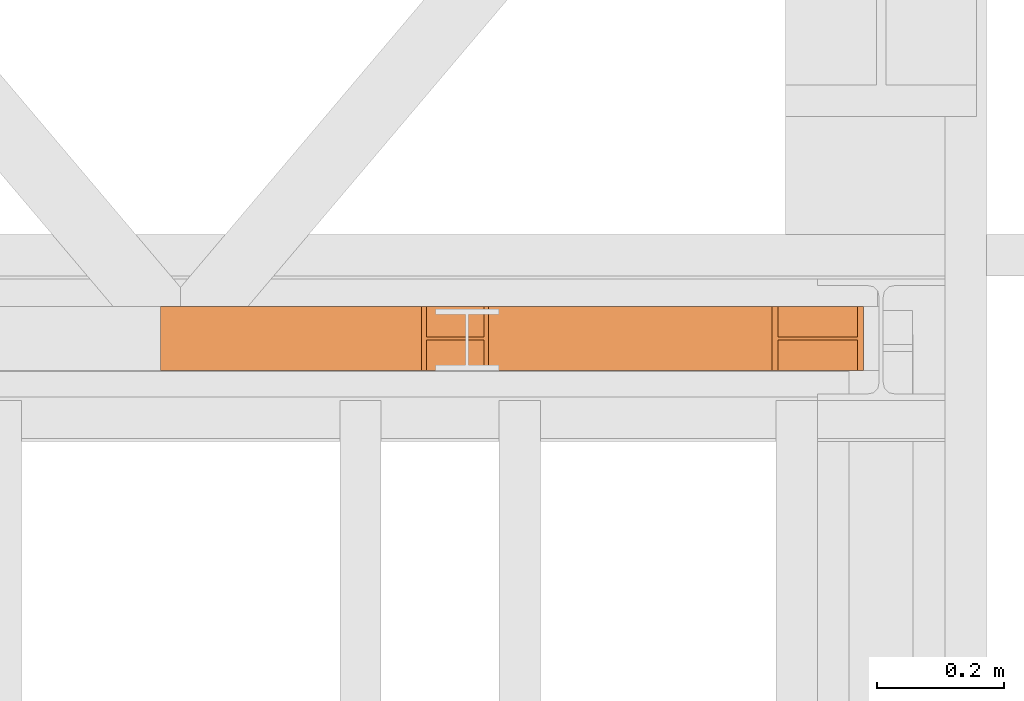
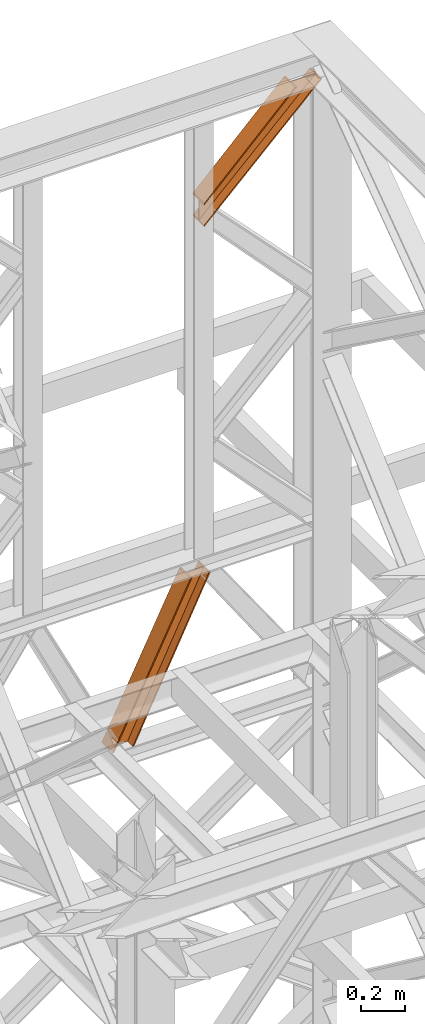
# One storey, part 207 of 208: 2 proxies.
"""IFC2X3 building model written with IfcOpenShell, lengths in millimetres."""

from ifc_helpers import new_model, entity, si_unit, converted_unit, frame, origin, origin_with_axes, place, context, subcontext, project, spatial, faceted_brep, element, save


model = new_model("IFC2X3")

# Units and contexts
model_context = context("Model", 3, precision=1e-05, world=origin())
plan_context = context("Plan", 3, precision=1e-05, world=origin())
body_context = subcontext(model_context, "Body", "Model", "MODEL_VIEW")
ifc_project = project(units=[si_unit("LENGTHUNIT", "METRE", prefix="MILLI"), converted_unit("PLANEANGLEUNIT", "DEGREE", entity("IfcPlaneAngleMeasure", 0.0174532925199433), si_unit("PLANEANGLEUNIT", "RADIAN"), dimensions=[0, 0, 0, 0, 0, 0, 0]), si_unit("AREAUNIT", "SQUARE_METRE"), si_unit("VOLUMEUNIT", "CUBIC_METRE")], contexts=[model_context, plan_context])

# Building, storey
building_placement = place(None, origin())
building = spatial("IfcBuilding", under=ifc_project, at=building_placement, CompositionType="COMPLEX")
storey_placement = place(building_placement, origin_with_axes())
storey = spatial("IfcBuildingStorey", under=building, at=storey_placement, Name="Geschoss", CompositionType="ELEMENT")

# Proxies
proxy_1_placement = place(storey_placement, frame((8143.254968528664, -13810.57439404318, 11640.28097264272), z_axis=(0.0, 0.0, 1.0), x_axis=(1.0, 0.0, 0.0)))
element("IfcBuildingElementProxy", 1, at=proxy_1_placement, inside=storey, context=body_context, shape_type="Brep", body=[
    faceted_brep([(487.7698797118947, 0.01000000000021828, 609.7190860510873), (0.01000000000112777, 0.01000000000021828, 120.9016769489845), (0.01000000000112777, 0.01000000000021828, 130.8127730178949), (478.5483619653542, 0.01000000000021828, 609.7190860510873), (478.5483619653542, 0.01000000000021828, 609.7190860510873), (0.01000000000112777, 0.01000000000021828, 130.8127730178949), (0.01000000000476575, 100.0100000000002, 130.8127730179022), (478.5483619653523, 100.0100000000002, 609.7190860510873), (478.5483619653523, 100.0100000000002, 609.7190860510873), (0.01000000000476575, 100.0100000000002, 130.8127730179022), (0.01000000000112777, 100.0100000000002, 120.9016769489845), (487.7698797118947, 100.0100000000002, 609.7190860510873), (487.7698797118947, 100.0100000000002, 609.7190860510873), (0.01000000000112777, 100.0100000000002, 120.9016769489845), (0.01000000000021828, 52.51000000000022, 120.9016769489808), (487.7698797118965, 52.51000000000022, 609.7190860510873), (487.7698797118965, 52.51000000000022, 609.7190860510873), (0.01000000000021828, 52.51000000000022, 120.9016769489808), (0.01000000000112777, 52.51000000000022, 9.871029833511784), (612.9405080443221, 52.51000000000022, 609.7190860510873), (612.9405080443221, 52.51000000000022, 609.7190860510873), (0.01000000000112777, 52.51000000000022, 9.871029833511784), (0.01000000000112777, 100.0100000000002, 9.871029833511784), (612.9405080443221, 100.0100000000002, 609.7190860510909), (612.9405080443221, 100.0100000000002, 609.7190860510909), (0.01000000000112777, 100.0100000000002, 9.871029833511784), (0.01000000000112777, 100.0100000000002, 0.01000000000021828), (622.1621300498164, 100.0100000000002, 609.7190860510909), (622.1621300498164, 100.0100000000002, 609.7190860510909), (0.01000000000112777, 100.0100000000002, 0.01000000000021828), (0.01000000000112777, 0.01000000000021828, 0.01000000000021828), (622.1621300498127, 0.01000000000021828, 609.7190860510837), (622.1621300498127, 0.01000000000021828, 609.7190860510837), (0.01000000000112777, 0.01000000000021828, 0.01000000000021828), (0.01000000000112777, 0.01000000000021828, 9.871029833511784), (612.9405080443166, 0.01000000000021828, 609.7190860510873), (612.9405080443166, 0.01000000000021828, 609.7190860510873), (0.01000000000112777, 0.01000000000021828, 9.871029833511784), (0.01000000000112777, 47.51000000000022, 9.871029833511784), (612.9405080443184, 47.51000000000022, 609.7190860510909), (612.9405080443184, 47.51000000000022, 609.7190860510909), (0.01000000000112777, 47.51000000000022, 9.871029833511784), (0.01000000000112777, 47.51000000000022, 120.9016769489845), (487.7698797118947, 47.51000000000022, 609.7190860510873), (487.7698797118947, 47.51000000000022, 609.7190860510873), (0.01000000000112777, 47.51000000000022, 120.9016769489845), (0.01000000000112777, 0.01000000000021828, 120.9016769489845), (487.7698797118947, 0.01000000000021828, 609.7190860510873), (0.01000000000112777, 0.01000000000021828, 120.9016769489845), (0.01000000000112777, 47.51000000000022, 120.9016769489845), (0.01000000000112777, 47.51000000000022, 9.871029833511784), (0.01000000000112777, 0.01000000000021828, 9.871029833511784), (0.01000000000112777, 0.01000000000021828, 0.01000000000021828), (0.01000000000112777, 100.0100000000002, 0.01000000000021828), (0.01000000000112777, 100.0100000000002, 9.871029833511784), (0.01000000000112777, 52.51000000000022, 9.871029833511784), (0.01000000000021828, 52.51000000000022, 120.9016769489808), (0.01000000000112777, 100.0100000000002, 120.9016769489845), (0.01000000000476575, 100.0100000000002, 130.8127730179022), (0.01000000000112777, 0.01000000000021828, 130.8127730178949), (478.5483619653542, 0.01000000000021828, 609.7190860510873), (478.5483619653523, 100.0100000000002, 609.7190860510873), (487.7698797118947, 100.0100000000002, 609.7190860510873), (487.7698797118965, 52.51000000000022, 609.7190860510873), (612.9405080443221, 52.51000000000022, 609.7190860510873), (612.9405080443221, 100.0100000000002, 609.7190860510909), (622.1621300498164, 100.0100000000002, 609.7190860510909), (622.1621300498127, 0.01000000000021828, 609.7190860510837), (612.9405080443166, 0.01000000000021828, 609.7190860510873), (612.9405080443184, 47.51000000000022, 609.7190860510909), (487.7698797118947, 47.51000000000022, 609.7190860510873), (487.7698797118947, 0.01000000000021828, 609.7190860510873)], [[[0, 1, 2, 3]], [[4, 5, 6, 7]], [[8, 9, 10, 11]], [[12, 13, 14, 15]], [[16, 17, 18, 19]], [[20, 21, 22, 23]], [[24, 25, 26, 27]], [[28, 29, 30, 31]], [[32, 33, 34, 35]], [[36, 37, 38, 39]], [[40, 41, 42, 43]], [[44, 45, 46, 47]], [[48, 49, 50, 51, 52, 53, 54, 55, 56, 57, 58, 59]], [[60, 61, 62, 63, 64, 65, 66, 67, 68, 69, 70, 71]]], orient=[[False], [False], [False], [False], [False], [False], [False], [False], [False], [False], [False], [False], [False], [False]]),
])
proxy_2_placement = place(storey_placement, frame((7661.963058466044, -13810.57439404318, 8881.007354628784), z_axis=(0.0, 0.0, 1.0), x_axis=(1.0, 0.0, 0.0)))
element("IfcBuildingElementProxy", 2, at=proxy_2_placement, inside=storey, context=body_context, shape_type="Brep", body=[
    faceted_brep([(0.01000000000021828, 0.01000000000021828, 0.01000000000021828), (409.9553058525798, 0.01000000000021828, 829.1083585935612), (417.6513064777428, 0.01000000000021828, 829.1083585935612), (7.199069198474717, 0.01000000000021828, 0.01000000000021828), (0.01000000000112777, 100.0100000000002, 0.01000000000021828), (409.9553058525835, 100.0100000000002, 829.1083585935612), (409.9553058525798, 0.01000000000021828, 829.1083585935612), (0.01000000000021828, 0.01000000000021828, 0.01000000000021828), (7.199069198474717, 100.0100000000002, 0.01000000000021828), (417.6513064777428, 100.0100000000002, 829.1083585935612), (409.9553058525835, 100.0100000000002, 829.1083585935612), (0.01000000000112777, 100.0100000000002, 0.01000000000021828), (7.199069198474717, 52.51000000000022, 0.01000000000385626), (417.6513064777428, 52.51000000000022, 829.1083585935612), (417.6513064777428, 100.0100000000002, 829.1083585935612), (7.199069198474717, 100.0100000000002, 0.01000000000021828), (105.6645407648803, 52.51000000000022, 0.01000000000021828), (507.4580362298721, 52.51000000000022, 829.1083585935612), (417.6513064777428, 52.51000000000022, 829.1083585935612), (7.199069198474717, 52.51000000000022, 0.01000000000385626), (105.6645407648784, 100.0100000000002, 0.01000000000021828), (507.4580362298684, 100.0100000000002, 829.1083585935612), (507.4580362298721, 52.51000000000022, 829.1083585935612), (105.6645407648803, 52.51000000000022, 0.01000000000021828), (112.8453822667971, 100.0100000000002, 0.01000000000021828), (515.1363869069501, 100.0100000000002, 829.1083585935612), (507.4580362298684, 100.0100000000002, 829.1083585935612), (105.6645407648784, 100.0100000000002, 0.01000000000021828), (112.8453822667971, 0.01000000000021828, 0.01000000000021828), (515.1363869069501, 0.01000000000021828, 829.1083585935612), (515.1363869069501, 100.0100000000002, 829.1083585935612), (112.8453822667971, 100.0100000000002, 0.01000000000021828), (105.6645407648784, 0.01000000000021828, 0.01000000000021828), (507.4580362298666, 0.01000000000021828, 829.1083585935612), (515.1363869069501, 0.01000000000021828, 829.1083585935612), (112.8453822667971, 0.01000000000021828, 0.01000000000021828), (105.6645407648766, 47.51000000000022, 0.01000000000021828), (507.4580362298666, 47.51000000000022, 829.1083585935612), (507.4580362298666, 0.01000000000021828, 829.1083585935612), (105.6645407648784, 0.01000000000021828, 0.01000000000021828), (7.199069198474717, 47.51000000000022, 0.01000000000385626), (417.6513064777428, 47.51000000000022, 829.1083585935612), (507.4580362298666, 47.51000000000022, 829.1083585935612), (105.6645407648766, 47.51000000000022, 0.01000000000021828), (7.199069198474717, 0.01000000000021828, 0.01000000000021828), (417.6513064777428, 0.01000000000021828, 829.1083585935612), (417.6513064777428, 47.51000000000022, 829.1083585935612), (7.199069198474717, 47.51000000000022, 0.01000000000385626), (409.9553058525798, 0.01000000000021828, 829.1083585935612), (409.9553058525835, 100.0100000000002, 829.1083585935612), (417.6513064777428, 100.0100000000002, 829.1083585935612), (417.6513064777428, 52.51000000000022, 829.1083585935612), (507.4580362298721, 52.51000000000022, 829.1083585935612), (507.4580362298684, 100.0100000000002, 829.1083585935612), (515.1363869069501, 100.0100000000002, 829.1083585935612), (515.1363869069501, 0.01000000000021828, 829.1083585935612), (507.4580362298666, 0.01000000000021828, 829.1083585935612), (507.4580362298666, 47.51000000000022, 829.1083585935612), (417.6513064777428, 47.51000000000022, 829.1083585935612), (417.6513064777428, 0.01000000000021828, 829.1083585935612), (7.199069198474717, 0.01000000000021828, 0.01000000000021828), (7.199069198474717, 47.51000000000022, 0.01000000000385626), (105.6645407648766, 47.51000000000022, 0.01000000000021828), (105.6645407648784, 0.01000000000021828, 0.01000000000021828), (112.8453822667971, 0.01000000000021828, 0.01000000000021828), (112.8453822667971, 100.0100000000002, 0.01000000000021828), (105.6645407648784, 100.0100000000002, 0.01000000000021828), (105.6645407648803, 52.51000000000022, 0.01000000000021828), (7.199069198474717, 52.51000000000022, 0.01000000000385626), (7.199069198474717, 100.0100000000002, 0.01000000000021828), (0.01000000000112777, 100.0100000000002, 0.01000000000021828), (0.01000000000021828, 0.01000000000021828, 0.01000000000021828)], [[[0, 1, 2, 3]], [[4, 5, 6, 7]], [[8, 9, 10, 11]], [[12, 13, 14, 15]], [[16, 17, 18, 19]], [[20, 21, 22, 23]], [[24, 25, 26, 27]], [[28, 29, 30, 31]], [[32, 33, 34, 35]], [[36, 37, 38, 39]], [[40, 41, 42, 43]], [[44, 45, 46, 47]], [[48, 49, 50, 51, 52, 53, 54, 55, 56, 57, 58, 59]], [[60, 61, 62, 63, 64, 65, 66, 67, 68, 69, 70, 71]]], orient=[[False], [False], [False], [False], [False], [False], [False], [False], [False], [False], [False], [False], [False], [False]]),
])

save(model, "model.ifc")
